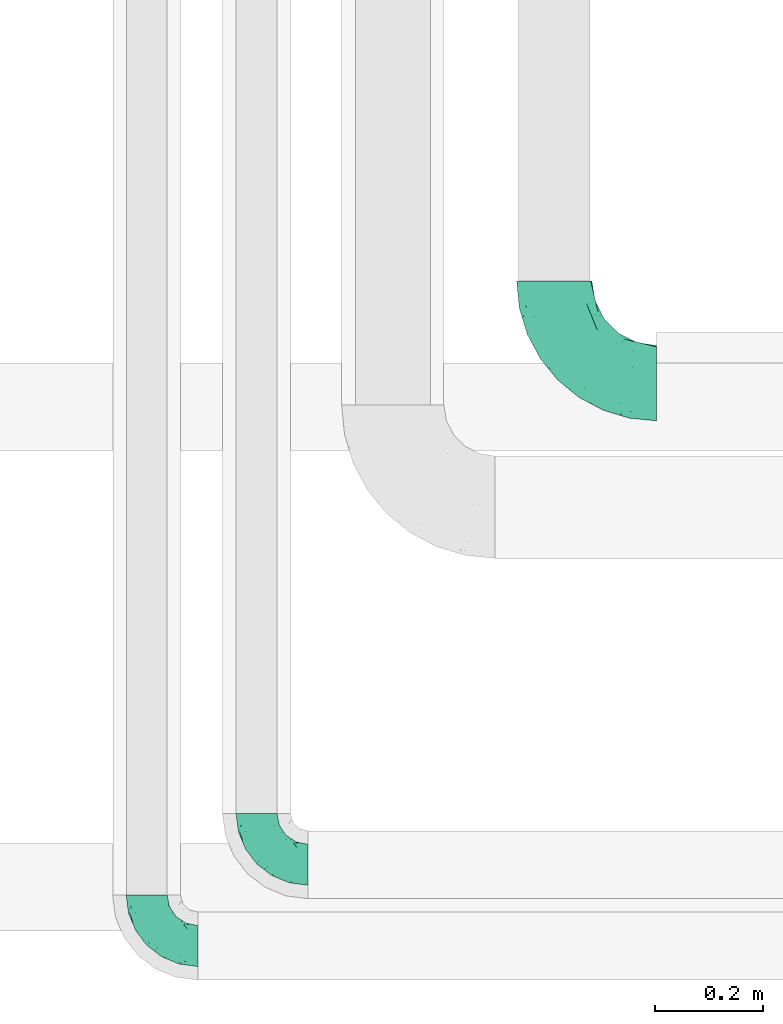
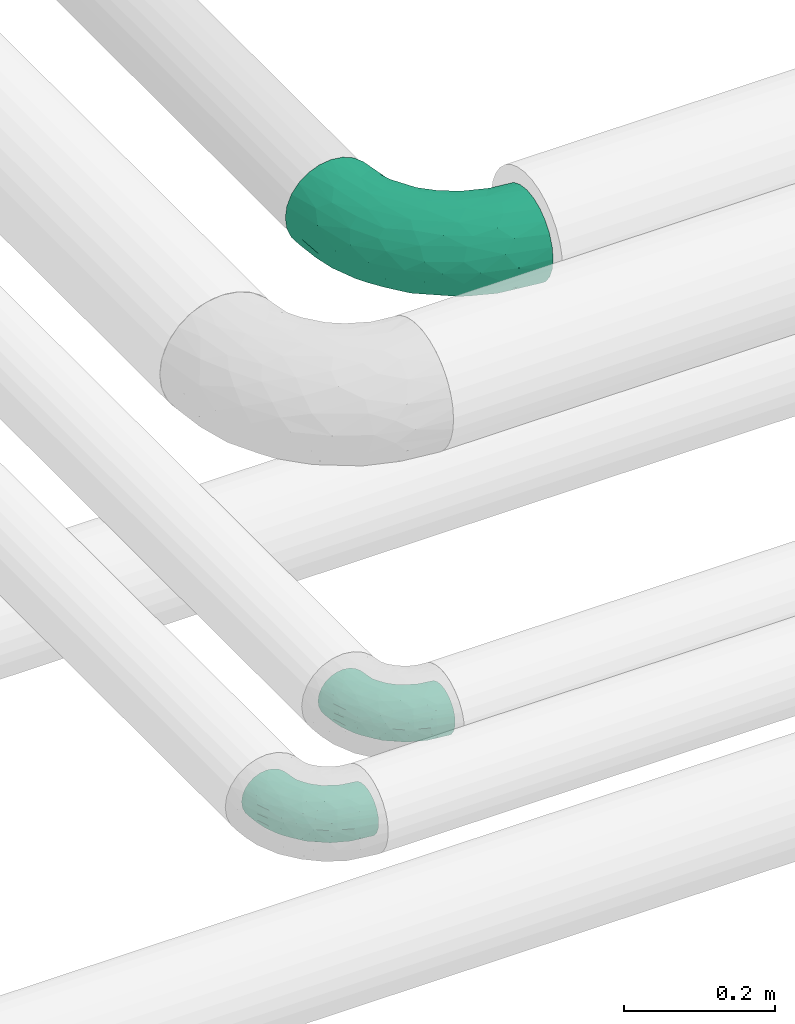
# One storey, part 551 of 827: 3 flow fittings.
"""IFC2X3 building model written with IfcOpenShell, lengths in millimetres."""

from ifc_helpers import new_model, entity, si_unit, converted_unit, derived_unit, direction, frame, origin, place, context, subcontext, project, spatial, faceted_brep, source, transform, mapped, material, type_object, type_shapes, element, save


model = new_model("IFC2X3")

# Units and contexts
model_context = context("Model", 3, precision=0.01, world=origin(), true_north=direction((6.12303176911189e-17, 1.0)))
body_context = subcontext(model_context, "Body", "Model", "MODEL_VIEW")
ifc_project = project(units=[si_unit("LENGTHUNIT", "METRE", prefix="MILLI"), si_unit("AREAUNIT", "SQUARE_METRE"), si_unit("VOLUMEUNIT", "CUBIC_METRE"), converted_unit("PLANEANGLEUNIT", "DEGREE", entity("IfcRatioMeasure", 0.0174532925199433), si_unit("PLANEANGLEUNIT", "RADIAN"), dimensions=[0, 0, 0, 0, 0, 0, 0]), si_unit("MASSUNIT", "GRAM", prefix="KILO"), derived_unit("MASSDENSITYUNIT", [(si_unit("MASSUNIT", "GRAM", prefix="KILO"), 1), (si_unit("LENGTHUNIT", "METRE"), -3)]), derived_unit("MOMENTOFINERTIAUNIT", [(si_unit("LENGTHUNIT", "METRE"), 4)]), si_unit("TIMEUNIT", "SECOND"), si_unit("FREQUENCYUNIT", "HERTZ"), si_unit("THERMODYNAMICTEMPERATUREUNIT", "DEGREE_CELSIUS"), derived_unit("THERMALTRANSMITTANCEUNIT", [(si_unit("MASSUNIT", "GRAM", prefix="KILO"), 1), (si_unit("THERMODYNAMICTEMPERATUREUNIT", "KELVIN"), -1), (si_unit("TIMEUNIT", "SECOND"), -3)]), derived_unit("VOLUMETRICFLOWRATEUNIT", [(si_unit("LENGTHUNIT", "METRE"), 3), (si_unit("TIMEUNIT", "SECOND"), -1)]), derived_unit("MASSFLOWRATEUNIT", [(si_unit("MASSUNIT", "GRAM", prefix="KILO"), 1), (si_unit("TIMEUNIT", "SECOND"), -1)]), derived_unit("ROTATIONALFREQUENCYUNIT", [(si_unit("TIMEUNIT", "SECOND"), -1)]), si_unit("ELECTRICCURRENTUNIT", "AMPERE"), si_unit("ELECTRICVOLTAGEUNIT", "VOLT"), si_unit("POWERUNIT", "WATT"), si_unit("FORCEUNIT", "NEWTON", prefix="KILO"), si_unit("ILLUMINANCEUNIT", "LUX"), si_unit("LUMINOUSFLUXUNIT", "LUMEN"), si_unit("LUMINOUSINTENSITYUNIT", "CANDELA"), derived_unit("USERDEFINED", [(si_unit("MASSUNIT", "GRAM", prefix="KILO"), -1), (si_unit("LENGTHUNIT", "METRE"), -2), (si_unit("TIMEUNIT", "SECOND"), 3), (si_unit("LUMINOUSFLUXUNIT", "LUMEN"), 1)]), derived_unit("LINEARVELOCITYUNIT", [(si_unit("LENGTHUNIT", "METRE"), 1), (si_unit("TIMEUNIT", "SECOND"), -1)]), si_unit("PRESSUREUNIT", "PASCAL"), derived_unit("USERDEFINED", [(si_unit("LENGTHUNIT", "METRE"), -2), (si_unit("MASSUNIT", "GRAM", prefix="KILO"), 1), (si_unit("TIMEUNIT", "SECOND"), -2)]), derived_unit("LINEARFORCEUNIT", [(si_unit("MASSUNIT", "GRAM", prefix="KILO"), 1), (si_unit("LENGTHUNIT", "METRE"), 1), (si_unit("TIMEUNIT", "SECOND"), -2), (si_unit("LENGTHUNIT", "METRE"), -1)]), derived_unit("PLANARFORCEUNIT", [(si_unit("MASSUNIT", "GRAM", prefix="KILO"), 1), (si_unit("LENGTHUNIT", "METRE"), 1), (si_unit("TIMEUNIT", "SECOND"), -2), (si_unit("LENGTHUNIT", "METRE"), -2)])], contexts=[model_context])

# Site, building, storey
site_placement = place(None, origin())
site = spatial("IfcSite", under=ifc_project, at=site_placement, CompositionType="ELEMENT")
building_placement = place(site_placement, origin())
building = spatial("IfcBuilding", under=site, at=building_placement, CompositionType="ELEMENT")
storey_placement = place(building_placement, frame((0.0, 0.0, 28200.0)))
storey = spatial("IfcBuildingStorey", under=building, at=storey_placement, Name="08", CompositionType="ELEMENT", Elevation=28200.0)

# Flow fittings
ifc_material = material()
pipe_fitting_type_1 = type_object("IfcPipeFittingType", Name="ADSK_1", PredefinedType="NOTDEFINED", material=ifc_material)
shared_shape_1 = source(origin(), body_context, "Body", "Brep", [
    faceted_brep([(-95.0, 19.02, -32.95), (-95.0, 9.85, -36.75), (-95.0, 0.0, -38.05), (-95.0, -9.85, -36.75), (-95.0, -19.03, -32.95), (-95.0, -26.91, -26.91), (-95.0, -32.95, -19.03), (-95.0, -36.75, -9.85), (-95.0, -38.05, 0.0), (-95.0, -36.75, 9.85), (-95.0, -32.95, 19.02), (-95.0, -26.91, 26.91), (-95.0, -19.03, 32.95), (-95.0, -9.85, 36.75), (-95.0, 0.0, 38.05), (-95.0, 9.85, 36.75), (-95.0, 19.02, 32.95), (-95.0, 26.91, 26.91), (-95.0, 32.95, 19.02), (-95.0, 36.75, 9.85), (-95.0, 38.05, 0.0), (-95.0, 36.75, -9.85), (-95.0, 32.95, -19.03), (-95.0, 26.91, -26.91), (0.0, 95.0, -38.05), (-9.85, 95.0, -36.75), (-19.02, 95.0, -32.95), (-26.91, 95.0, -26.91), (-32.95, 95.0, -19.03), (-36.75, 95.0, -9.85), (-38.05, 95.0, 0.0), (-36.75, 95.0, 9.85), (-32.95, 95.0, 19.02), (-26.91, 95.0, 26.91), (-19.02, 95.0, 32.95), (-9.85, 95.0, 36.75), (0.0, 95.0, 38.05), (9.85, 95.0, 36.75), (19.03, 95.0, 32.95), (26.91, 95.0, 26.91), (32.95, 95.0, 19.02), (36.75, 95.0, 9.85), (38.05, 95.0, 0.0), (36.75, 95.0, -9.85), (32.95, 95.0, -19.03), (26.91, 95.0, -26.91), (19.03, 95.0, -32.95), (9.85, 95.0, -36.75), (-7.99, -4.96, 6.3), (-0.92, 0.92, 0.0), (4.62, 8.1, 8.01), (-76.19, -35.57, 0.0), (-64.32, -32.32, 12.43), (20.51, 62.45, 28.68), (-60.56, -33.52, 0.0), (-70.4, -13.47, 34.42), (-39.61, -5.88, 32.32), (-49.6, 2.07, 37.1), (-70.34, -28.81, 21.71), (14.64, 40.81, 26.5), (5.88, 39.61, 32.32), (3.59, 20.77, 25.31), (-40.45, 68.06, 16.75), (-62.45, -20.51, 28.68), (-44.52, -26.87, 0.0), (-28.47, -20.22, 0.0), (-26.43, -17.83, 8.75), (-76.1, 39.63, 10.76), (-72.74, 37.58, 18.19), (-60.35, 46.18, 14.61), (-13.4, 13.4, 32.12), (-20.77, -3.59, 25.31), (-14.66, 81.47, 35.56), (-6.22, 71.26, 37.92), (-57.5, 42.48, 22.79), (-15.0, 34.74, 37.7), (-27.1, 12.08, 36.05), (-9.2, 28.81, 35.63), (-79.98, 23.7, 30.95), (-73.68, -4.3, 37.48), (-30.74, 21.67, 37.97), (-62.36, 47.59, 6.79), (-72.71, 32.83, 24.69), (-67.42, 7.02, 37.95), (-32.13, 75.27, 24.51), (-43.46, 51.47, 26.26), (-24.98, 73.15, 31.29), (20.59, 41.28, 19.85), (7.79, 16.09, 15.86), (-73.21, 42.39, 0.0), (-54.73, 54.73, 0.0), (-73.44, 15.79, 35.79), (-5.94, 4.32, 20.43), (28.81, 70.34, 21.71), (32.32, 64.32, 12.43), (-53.59, 26.2, 35.09), (-52.02, 19.31, 37.21), (21.38, 33.53, 10.34), (26.87, 44.52, 0.0), (-48.28, 12.14, 38.05), (4.3, 73.68, 37.48), (-44.08, -25.52, 12.79), (-41.28, -20.59, 19.85), (35.57, 76.19, 0.0), (-47.26, 54.3, 20.18), (-47.4, 61.99, 8.58), (-42.39, 73.21, 0.0), (-39.67, 78.86, 7.21), (-45.69, 36.84, 33.11), (-32.83, 50.13, 33.35), (13.47, 70.4, 34.42), (-18.25, 63.73, 36.07), (-40.63, -13.75, 27.22), (-16.63, 46.37, 37.95), (-53.47, 38.79, 28.59), (-26.07, 48.54, 36.15), (-34.51, 34.51, 36.86), (-2.07, 49.6, 37.1), (-22.79, -10.49, 19.23), (-61.73, 28.67, 31.87), (9.65, 14.7, 0.0), (20.22, 28.47, 0.0), (33.52, 60.56, 0.0), (-11.42, -5.44, 13.25), (-14.7, -9.65, 0.0), (-81.47, 14.66, -35.56), (-62.45, -20.51, -28.68), (-71.26, 6.22, -37.92), (-75.27, 32.13, -24.51), (-73.15, 24.98, -31.29), (13.47, 70.4, -34.42), (5.88, 39.61, -32.32), (-2.07, 49.6, -37.1), (-78.86, 39.67, -7.21), (-70.4, -13.47, -34.42), (-39.61, -5.88, -32.32), (-61.99, 47.4, -8.58), (32.32, 64.32, -12.43), (28.81, 70.34, -21.71), (-63.73, 18.25, -36.07), (-50.13, 32.83, -33.35), (4.3, 73.68, -37.48), (-7.02, 67.42, -37.95), (-39.63, 76.1, -10.76), (-46.18, 60.35, -14.61), (-47.59, 62.36, -6.79), (-64.32, -32.32, -12.43), (-26.2, 53.59, -35.09), (-15.79, 73.44, -35.79), (-19.31, 52.02, -37.21), (-37.58, 72.74, -18.19), (-70.34, -28.81, -21.71), (-42.48, 57.5, -22.79), (-38.79, 53.47, -28.59), (-51.47, 43.46, -26.26), (-32.83, 72.71, -24.69), (-46.37, 16.63, -37.95), (-73.68, -4.3, -37.48), (-41.28, -20.59, -19.85), (-44.08, -25.52, -12.79), (13.75, 40.63, -27.22), (20.51, 62.45, -28.68), (-68.06, 40.45, -16.75), (-54.3, 47.26, -20.18), (-12.14, 48.28, -38.05), (-21.67, 30.74, -37.97), (-36.84, 45.69, -33.11), (-11.42, -5.44, -13.25), (7.79, 16.09, -15.86), (4.62, 8.1, -8.01), (-23.7, 79.98, -30.95), (-26.43, -17.83, -8.75), (-7.99, -4.96, -6.3), (-40.81, -14.64, -26.5), (-20.77, -3.59, -25.31), (-34.74, 15.0, -37.7), (-12.08, 27.1, -36.05), (-28.81, 9.2, -35.63), (-22.79, -10.49, -19.23), (21.38, 33.53, -10.34), (20.59, 41.28, -19.85), (-48.54, 26.07, -36.15), (-49.6, 2.07, -37.1), (-13.4, 13.4, -32.12), (3.59, 20.77, -25.31), (-28.67, 61.73, -31.87), (-34.51, 34.51, -36.86), (-5.94, 4.32, -20.43)], [[[0, 1, 2, 3, 4, 5, 6, 7, 8, 9, 10, 11, 12, 13, 14, 15, 16, 17, 18, 19, 20, 21, 22, 23]], [[24, 25, 26, 27, 28, 29, 30, 31, 32, 33, 34, 35, 36, 37, 38, 39, 40, 41, 42, 43, 44, 45, 46, 47]], [[48, 49, 50]], [[51, 52, 9]], [[53, 39, 38]], [[9, 52, 10]], [[54, 52, 51]], [[55, 56, 57]], [[11, 10, 58]], [[59, 60, 61]], [[32, 31, 62]], [[63, 12, 11]], [[63, 55, 12]], [[64, 65, 66]], [[67, 68, 69]], [[70, 56, 71]], [[35, 72, 73]], [[69, 68, 74]], [[75, 76, 77]], [[16, 78, 17]], [[13, 79, 14]], [[76, 75, 80]], [[67, 69, 81]], [[18, 17, 82]], [[14, 79, 83]], [[20, 19, 67]], [[84, 85, 86]], [[87, 61, 88]], [[89, 81, 90]], [[18, 82, 68]], [[15, 91, 16]], [[14, 83, 15]], [[71, 92, 61]], [[17, 78, 82]], [[93, 87, 94]], [[95, 91, 96]], [[97, 98, 94]], [[86, 72, 34]], [[96, 99, 80]], [[37, 36, 100]], [[40, 39, 93]], [[40, 94, 41]], [[64, 66, 101]], [[93, 94, 40]], [[58, 102, 63]], [[94, 103, 41]], [[94, 87, 97]], [[104, 69, 74]], [[34, 33, 86]], [[105, 69, 104]], [[52, 58, 10]], [[106, 107, 30]], [[108, 109, 85]], [[105, 106, 90]], [[53, 110, 60]], [[86, 111, 72]], [[86, 109, 111]], [[33, 84, 86]], [[12, 55, 13]], [[112, 56, 63]], [[110, 38, 37]], [[34, 72, 35]], [[36, 35, 73]], [[111, 113, 73]], [[105, 107, 106]], [[110, 53, 38]], [[74, 114, 85]], [[91, 15, 83]], [[105, 90, 81]], [[107, 62, 31]], [[33, 32, 84]], [[115, 109, 116]], [[111, 115, 113]], [[100, 73, 117]], [[56, 55, 63]], [[79, 55, 57]], [[102, 118, 112]], [[56, 70, 76]], [[100, 110, 37]], [[117, 77, 60]], [[117, 60, 110]], [[60, 70, 61]], [[58, 52, 101]], [[63, 11, 58]], [[39, 53, 93]], [[87, 93, 53]], [[96, 91, 83]], [[78, 91, 119]], [[32, 62, 84]], [[84, 62, 104]], [[86, 85, 109]], [[85, 114, 108]], [[80, 113, 116]], [[117, 73, 113]], [[80, 116, 96]], [[80, 57, 76]], [[71, 112, 118]], [[61, 87, 59]], [[62, 107, 105]], [[97, 120, 121]], [[70, 71, 61]], [[71, 118, 92]], [[73, 100, 36]], [[110, 100, 117]], [[55, 79, 13]], [[83, 79, 57]], [[96, 83, 99]], [[116, 108, 95]], [[50, 97, 88]], [[97, 87, 88]], [[50, 49, 120]], [[122, 94, 98]], [[89, 20, 67]], [[105, 81, 69]], [[89, 67, 81]], [[68, 19, 18]], [[68, 67, 19]], [[74, 68, 82]], [[114, 82, 119]], [[74, 85, 104]], [[82, 114, 74]], [[114, 119, 108]], [[95, 108, 119]], [[116, 109, 108]], [[123, 48, 50]], [[97, 50, 120]], [[123, 50, 88]], [[91, 95, 119]], [[116, 95, 96]], [[84, 104, 85]], [[104, 62, 105]], [[83, 57, 99]], [[57, 80, 99]], [[66, 48, 123]], [[66, 124, 48]], [[118, 66, 123]], [[124, 66, 65]], [[66, 118, 101]], [[54, 64, 52]], [[124, 49, 48]], [[30, 107, 31]], [[91, 78, 16]], [[82, 78, 119]], [[56, 76, 57]], [[77, 76, 70]], [[60, 77, 70]], [[77, 117, 75]], [[117, 113, 75]], [[113, 80, 75]], [[9, 8, 51]], [[103, 94, 122]], [[103, 42, 41]], [[73, 72, 111]], [[113, 115, 116]], [[111, 109, 115]], [[102, 112, 63]], [[71, 56, 112]], [[118, 102, 101]], [[92, 123, 88]], [[123, 92, 118]], [[61, 92, 88]], [[87, 53, 59]], [[60, 59, 53]], [[97, 121, 98]], [[58, 101, 102]], [[64, 101, 52]], [[125, 1, 0]], [[126, 5, 4]], [[2, 1, 127]], [[1, 125, 127]], [[128, 129, 23]], [[130, 131, 132]], [[89, 133, 20]], [[126, 134, 135]], [[136, 89, 90]], [[137, 138, 44]], [[139, 129, 140]], [[24, 141, 142]], [[143, 144, 145]], [[125, 129, 139]], [[6, 146, 7]], [[147, 148, 149]], [[146, 51, 7]], [[143, 150, 144]], [[146, 6, 151]], [[152, 153, 154]], [[126, 4, 134]], [[0, 23, 129]], [[28, 155, 150]], [[43, 42, 103]], [[54, 146, 64]], [[139, 156, 127]], [[157, 3, 2]], [[151, 158, 159]], [[160, 131, 161]], [[22, 21, 162]], [[136, 144, 163]], [[149, 164, 165]], [[24, 142, 25]], [[166, 140, 154]], [[154, 129, 128]], [[143, 30, 29]], [[167, 168, 169]], [[155, 28, 27]], [[26, 170, 27]], [[171, 167, 172]], [[26, 25, 148]], [[27, 170, 155]], [[173, 135, 174]], [[144, 150, 152]], [[175, 176, 177]], [[24, 47, 141]], [[45, 161, 46]], [[148, 25, 142]], [[176, 175, 165]], [[64, 159, 171]], [[138, 45, 44]], [[130, 46, 161]], [[137, 44, 43]], [[178, 159, 158]], [[137, 103, 122]], [[163, 144, 152]], [[136, 133, 89]], [[103, 137, 43]], [[6, 5, 151]], [[178, 158, 173]], [[134, 4, 3]], [[178, 173, 174]], [[137, 98, 179]], [[145, 90, 106]], [[138, 180, 161]], [[46, 130, 47]], [[136, 90, 145]], [[133, 162, 21]], [[23, 22, 128]], [[139, 140, 181]], [[139, 181, 156]], [[157, 127, 182]], [[157, 134, 3]], [[182, 177, 135]], [[182, 135, 134]], [[135, 183, 174]], [[131, 130, 161]], [[141, 130, 132]], [[160, 180, 184]], [[131, 183, 176]], [[5, 126, 151]], [[158, 151, 126]], [[180, 138, 137]], [[161, 45, 138]], [[149, 148, 142]], [[170, 148, 185]], [[22, 162, 128]], [[128, 162, 163]], [[129, 154, 140]], [[154, 153, 166]], [[165, 156, 186]], [[182, 127, 156]], [[165, 186, 149]], [[165, 132, 176]], [[131, 184, 183]], [[187, 167, 178]], [[184, 168, 187]], [[167, 169, 172]], [[184, 180, 168]], [[174, 183, 184]], [[127, 157, 2]], [[134, 157, 182]], [[130, 141, 47]], [[142, 141, 132]], [[149, 142, 164]], [[186, 166, 147]], [[180, 179, 168]], [[169, 179, 120]], [[137, 179, 180]], [[179, 121, 120]], [[106, 30, 143]], [[136, 145, 144]], [[106, 143, 145]], [[150, 29, 28]], [[150, 143, 29]], [[152, 150, 155]], [[153, 155, 185]], [[152, 154, 163]], [[155, 153, 152]], [[153, 185, 166]], [[147, 166, 185]], [[186, 140, 166]], [[169, 120, 49]], [[169, 49, 172]], [[179, 169, 168]], [[148, 147, 185]], [[186, 147, 149]], [[128, 163, 154]], [[163, 162, 136]], [[142, 132, 164]], [[132, 165, 164]], [[171, 124, 65]], [[124, 171, 172]], [[64, 146, 159]], [[171, 159, 178]], [[171, 65, 64]], [[172, 49, 124]], [[162, 133, 136]], [[20, 133, 21]], [[148, 170, 26]], [[155, 170, 185]], [[131, 176, 132]], [[177, 176, 183]], [[135, 177, 183]], [[177, 182, 175]], [[182, 156, 175]], [[156, 165, 175]], [[51, 146, 54]], [[51, 8, 7]], [[129, 125, 0]], [[127, 125, 139]], [[140, 186, 181]], [[156, 181, 186]], [[158, 126, 173]], [[135, 173, 126]], [[187, 178, 174]], [[171, 178, 167]], [[184, 187, 174]], [[167, 187, 168]], [[180, 160, 161]], [[184, 131, 160]], [[98, 137, 122]], [[98, 121, 179]], [[151, 159, 146]]]),
])
type_shapes(pipe_fitting_type_1, [shared_shape_1])
for number, where, z_axis, x_axis, name in (
    (1, (26663.64, 6265.71, 3100.0), (0.0, 0.0, 1.0), (0.0, -1.0, 0.0), "ADSK_1"),
    (2, (26867.64, 6416.57, 3100.0), (0.0, 0.0, 1.0), (0.0, -1.0, 0.0), "ADSK_1"),
):
    element("IfcFlowFitting", number, at=place(storey_placement, frame(where, z_axis=z_axis, x_axis=x_axis)), inside=storey, type_object=pipe_fitting_type_1, material=ifc_material, Name=name, ObjectType="ADSK_1", context=body_context, shape_type="MappedRepresentation", body=[
        mapped(shared_shape_1, transform((0.0, 0.0, 0.0), scale=1.0)),
    ])
pipe_fitting_type_2 = type_object("IfcPipeFittingType", Name="ADSK_1", PredefinedType="NOTDEFINED", material=ifc_material)
shared_shape_2 = source(origin(), body_context, "Body", "Brep", [
    faceted_brep([(-190.0, 18.08, -67.47), (-190.0, 0.0, -69.85), (-190.0, -18.08, -67.47), (-190.0, -34.93, -60.49), (-190.0, -49.39, -49.39), (-190.0, -60.49, -34.93), (-190.0, -67.47, -18.08), (-190.0, -69.85, 0.0), (-190.0, -67.47, 18.08), (-190.0, -60.49, 34.92), (-190.0, -49.39, 49.39), (-190.0, -34.93, 60.49), (-190.0, -18.08, 67.47), (-190.0, 0.0, 69.85), (-190.0, 18.08, 67.47), (-190.0, 34.92, 60.49), (-190.0, 49.39, 49.39), (-190.0, 60.49, 34.92), (-190.0, 67.47, 18.08), (-190.0, 69.85, 0.0), (-190.0, 67.47, -18.08), (-190.0, 60.49, -34.93), (-190.0, 49.39, -49.39), (-190.0, 34.92, -60.49), (18.08, 190.0, -67.47), (0.0, 190.0, -69.85), (-18.08, 190.0, -67.47), (-34.92, 190.0, -60.49), (-49.39, 190.0, -49.39), (-60.49, 190.0, -34.93), (-67.47, 190.0, -18.08), (-69.85, 190.0, 0.0), (-67.47, 190.0, 18.08), (-60.49, 190.0, 34.92), (-49.39, 190.0, 49.39), (-34.92, 190.0, 60.49), (-18.08, 190.0, 67.47), (0.0, 190.0, 69.85), (18.08, 190.0, 67.47), (34.93, 190.0, 60.49), (49.39, 190.0, 49.39), (60.49, 190.0, 34.92), (67.47, 190.0, 18.08), (69.85, 190.0, 0.0), (67.47, 190.0, -18.08), (60.49, 190.0, -34.93), (49.39, 190.0, -49.39), (34.93, 190.0, -60.49), (-29.62, 146.98, 65.62), (-13.75, 135.37, 69.64), (-124.22, -36.33, 52.83), (-140.23, -52.18, 40.04), (-80.56, -34.09, 36.78), (-140.97, -24.01, 63.29), (-80.93, -8.05, 59.8), (-100.59, 5.62, 68.24), (-125.19, -57.65, 22.9), (-139.31, -64.86, 0.0), (-28.7, -8.91, 22.6), (-45.64, -26.06, 0.0), (-6.26, 6.26, 0.0), (-105.44, 36.89, 68.2), (-118.83, 43.56, 64.34), (-146.98, 29.62, 65.62), (-71.47, -38.86, 17.07), (-90.56, -50.07, 0.0), (-0.6, 27.02, 35.97), (-44.76, -2.31, 47.74), (-42.86, -12.1, 35.78), (-148.03, -7.38, 68.85), (-135.37, 13.75, 69.64), (-67.48, 159.11, 28.79), (36.32, 124.15, 52.82), (-38.8, 102.11, 68.2), (-24.59, 96.61, 69.85), (-81.73, 130.22, 21.92), (-65.15, 30.31, 68.68), (-27.72, 54.52, 66.49), (-44.98, 61.25, 69.74), (-75.73, 152.87, 0.0), (-159.11, 67.48, 28.79), (-130.22, 81.73, 21.92), (-152.87, 75.73, 0.0), (-76.65, 126.59, 35.57), (-101.51, 101.51, 25.92), (-96.74, 96.74, 38.75), (-144.94, 60.97, 45.11), (-159.57, 43.91, 56.71), (-119.38, 92.8, 0.0), (50.07, 90.56, 0.0), (57.42, 124.25, 22.84), (38.8, 71.6, 17.49), (64.86, 139.31, 0.0), (52.17, 140.21, 40.03), (33.37, 79.39, 36.99), (24.0, 140.95, 63.29), (8.03, 80.92, 59.81), (-82.61, -22.17, 50.94), (7.38, 148.03, 68.85), (-100.26, 79.14, 51.33), (-75.76, 96.1, 55.72), (-76.12, 111.95, 46.7), (-92.8, 119.38, 0.0), (-104.27, 104.27, 12.31), (10.07, 27.17, 16.15), (26.06, 45.64, 0.0), (-61.21, 144.14, 45.16), (-44.13, 158.15, 56.77), (-55.26, 120.41, 58.38), (9.95, 57.03, 48.64), (29.48, 90.08, 47.56), (-5.62, 100.59, 68.24), (-122.78, 54.24, 58.28), (-86.25, 73.26, 61.12), (-95.79, 24.47, 69.85), (-126.59, 76.65, 35.57), (-17.15, 26.56, 50.85), (-29.82, 29.82, 59.54), (-70.73, 11.02, 65.19), (-58.6, 94.58, 64.16), (-71.14, 66.1, 67.41), (-158.15, 44.13, -56.77), (33.37, 79.39, -36.99), (10.07, 27.17, -16.15), (-0.6, 27.02, -35.97), (-100.59, 5.62, -68.24), (-148.03, -7.38, -68.85), (-135.37, 13.75, -69.64), (-130.22, 81.73, -21.92), (-146.98, 29.62, -65.62), (-102.11, 38.8, -68.2), (-96.61, 24.59, -69.85), (-83.02, -24.86, -48.76), (-44.76, -2.31, -47.74), (-80.56, -34.09, -36.78), (-122.68, -57.24, -22.15), (-71.43, -38.87, -16.95), (-104.27, 104.27, -12.31), (-159.11, 67.48, -28.79), (-144.14, 61.21, -45.16), (7.38, 148.03, -68.85), (-13.75, 135.37, -69.64), (-79.14, 100.26, -51.33), (-96.1, 75.76, -55.72), (-111.95, 76.12, -46.7), (-80.93, -8.05, -59.8), (-124.22, -36.33, -52.83), (-140.23, -52.18, -40.04), (-24.47, 95.79, -69.85), (-36.89, 105.44, -68.2), (-150.18, -65.36, -13.92), (-43.56, 118.83, -64.34), (-29.62, 146.98, -65.62), (38.8, 71.6, -17.49), (-81.73, 130.22, -21.92), (-28.7, -8.91, -22.6), (-54.24, 122.78, -58.28), (-73.26, 86.25, -61.12), (-61.25, 44.98, -69.74), (-30.31, 65.15, -68.68), (-54.52, 27.72, -66.49), (-101.51, 101.51, -25.92), (-126.59, 76.65, -35.57), (-96.74, 96.74, -38.75), (-67.48, 159.11, -28.79), (-120.41, 55.26, -58.38), (-43.91, 159.57, -56.71), (24.0, 140.95, -63.29), (8.03, 80.92, -59.81), (-5.62, 100.59, -68.24), (-60.97, 144.94, -45.11), (36.32, 124.15, -52.82), (57.42, 124.25, -22.84), (52.17, 140.21, -40.03), (-140.97, -24.01, -63.29), (9.95, 57.03, -48.64), (-76.65, 126.59, -35.57), (22.84, 89.04, -52.94), (-11.03, 70.74, -65.2), (-29.82, 29.82, -59.54), (-94.58, 58.6, -64.16), (-66.1, 71.14, -67.41), (-31.42, -3.01, -36.09), (-13.88, 24.32, -46.86)], [[[0, 1, 2, 3, 4, 5, 6, 7, 8, 9, 10, 11, 12, 13, 14, 15, 16, 17, 18, 19, 20, 21, 22, 23]], [[24, 25, 26, 27, 28, 29, 30, 31, 32, 33, 34, 35, 36, 37, 38, 39, 40, 41, 42, 43, 44, 45, 46, 47]], [[36, 48, 49]], [[50, 51, 52]], [[53, 54, 55]], [[56, 9, 8]], [[8, 7, 57]], [[58, 59, 60]], [[51, 9, 56]], [[61, 62, 63]], [[59, 58, 64]], [[59, 64, 65]], [[11, 10, 50]], [[66, 67, 68]], [[50, 53, 11]], [[69, 70, 13]], [[71, 33, 32]], [[72, 40, 39]], [[73, 74, 49]], [[63, 15, 14]], [[13, 70, 14]], [[71, 32, 75]], [[12, 69, 13]], [[76, 77, 78]], [[32, 79, 75]], [[18, 80, 81]], [[63, 14, 70]], [[82, 19, 18]], [[83, 84, 85]], [[86, 16, 87]], [[82, 81, 88]], [[82, 18, 81]], [[15, 87, 16]], [[83, 71, 75]], [[52, 56, 64]], [[49, 37, 36]], [[89, 90, 91]], [[36, 35, 48]], [[42, 41, 90]], [[89, 92, 90]], [[11, 53, 12]], [[73, 78, 74]], [[65, 56, 57]], [[40, 72, 93]], [[94, 90, 93]], [[41, 40, 93]], [[72, 95, 96]], [[95, 39, 38]], [[8, 57, 56]], [[43, 42, 92]], [[67, 54, 97]], [[38, 37, 98]], [[99, 100, 101]], [[102, 75, 79]], [[51, 10, 9]], [[102, 88, 103]], [[31, 79, 32]], [[104, 60, 105]], [[106, 34, 33]], [[84, 103, 81]], [[91, 105, 89]], [[107, 35, 34]], [[106, 108, 107]], [[49, 48, 73]], [[104, 105, 91]], [[16, 86, 17]], [[58, 104, 66]], [[109, 110, 96]], [[111, 98, 49]], [[112, 113, 99]], [[92, 42, 90]], [[95, 72, 39]], [[70, 114, 61]], [[80, 18, 17]], [[101, 106, 83]], [[99, 86, 112]], [[115, 81, 80]], [[90, 94, 91]], [[94, 66, 104]], [[64, 58, 68]], [[56, 65, 64]], [[93, 72, 110]], [[90, 41, 93]], [[98, 95, 38]], [[111, 77, 96]], [[111, 96, 95]], [[67, 116, 117]], [[52, 51, 56]], [[50, 10, 51]], [[54, 53, 50]], [[69, 53, 55]], [[97, 52, 67]], [[118, 76, 55]], [[107, 48, 35]], [[73, 119, 120]], [[61, 63, 70]], [[63, 62, 87]], [[94, 104, 91]], [[58, 60, 104]], [[109, 66, 94]], [[67, 117, 54]], [[68, 67, 52]], [[116, 66, 109]], [[119, 48, 108]], [[73, 120, 78]], [[120, 61, 114]], [[78, 114, 76]], [[49, 98, 37]], [[95, 98, 111]], [[53, 69, 12]], [[70, 69, 55]], [[70, 55, 114]], [[120, 113, 62]], [[76, 114, 55]], [[120, 114, 78]], [[118, 55, 54]], [[76, 118, 77]], [[96, 77, 117]], [[111, 78, 77]], [[54, 117, 118]], [[77, 118, 117]], [[110, 109, 94]], [[116, 96, 117]], [[106, 107, 34]], [[48, 107, 108]], [[75, 84, 83]], [[106, 33, 71]], [[101, 83, 85]], [[106, 71, 83]], [[99, 101, 85]], [[108, 106, 101]], [[99, 85, 115]], [[113, 112, 62]], [[119, 113, 120]], [[100, 99, 113]], [[17, 86, 80]], [[115, 85, 84]], [[80, 86, 115]], [[99, 115, 86]], [[63, 87, 15]], [[86, 87, 112]], [[78, 111, 74]], [[111, 49, 74]], [[119, 100, 113]], [[101, 100, 108]], [[48, 119, 73]], [[119, 108, 100]], [[75, 102, 103]], [[115, 84, 81]], [[81, 103, 88]], [[75, 103, 84]], [[54, 50, 97]], [[52, 97, 50]], [[64, 68, 52]], [[66, 68, 58]], [[62, 61, 120]], [[87, 62, 112]], [[93, 110, 94]], [[96, 110, 72]], [[66, 116, 67]], [[96, 116, 109]], [[22, 121, 23]], [[122, 123, 124]], [[125, 126, 127]], [[20, 82, 128]], [[129, 130, 127]], [[130, 131, 127]], [[19, 82, 20]], [[132, 133, 134]], [[88, 128, 82]], [[135, 136, 65]], [[102, 137, 88]], [[138, 20, 128]], [[139, 22, 21]], [[140, 141, 25]], [[142, 143, 144]], [[145, 133, 132]], [[4, 146, 147]], [[141, 148, 149]], [[7, 6, 150]], [[138, 21, 20]], [[5, 4, 147]], [[149, 151, 152]], [[59, 65, 136]], [[122, 153, 123]], [[79, 30, 154]], [[134, 155, 136]], [[150, 65, 57]], [[156, 157, 142]], [[126, 2, 1]], [[134, 135, 147]], [[130, 158, 131]], [[159, 160, 158]], [[154, 161, 137]], [[0, 23, 129]], [[127, 1, 0]], [[162, 138, 128]], [[161, 163, 162]], [[30, 79, 31]], [[146, 4, 3]], [[154, 30, 164]], [[152, 27, 26]], [[165, 121, 139]], [[25, 24, 140]], [[25, 141, 26]], [[164, 30, 29]], [[27, 166, 28]], [[167, 168, 169]], [[141, 152, 26]], [[28, 170, 29]], [[47, 171, 167]], [[172, 89, 153]], [[59, 155, 60]], [[28, 166, 170]], [[46, 45, 173]], [[153, 89, 105]], [[105, 123, 153]], [[174, 146, 3]], [[171, 47, 46]], [[45, 44, 172]], [[7, 150, 57]], [[43, 92, 44]], [[122, 124, 175]], [[89, 172, 92]], [[171, 173, 122]], [[47, 167, 24]], [[173, 171, 46]], [[135, 150, 5]], [[0, 129, 127]], [[174, 3, 2]], [[79, 154, 102]], [[146, 174, 145]], [[44, 92, 172]], [[144, 139, 162]], [[142, 170, 156]], [[176, 154, 164]], [[105, 60, 123]], [[122, 172, 153]], [[45, 172, 173]], [[122, 173, 172]], [[167, 171, 177]], [[140, 167, 169]], [[177, 122, 175]], [[178, 159, 169]], [[134, 136, 135]], [[155, 59, 136]], [[134, 147, 146]], [[135, 5, 147]], [[126, 174, 2]], [[125, 160, 145]], [[125, 145, 174]], [[145, 179, 133]], [[121, 129, 23]], [[130, 180, 181]], [[149, 152, 141]], [[152, 151, 166]], [[60, 155, 123]], [[123, 155, 124]], [[182, 134, 133]], [[175, 179, 168]], [[183, 179, 175]], [[155, 182, 124]], [[180, 129, 165]], [[130, 181, 158]], [[181, 149, 148]], [[158, 148, 159]], [[127, 126, 1]], [[174, 126, 125]], [[167, 140, 24]], [[141, 140, 169]], [[141, 169, 148]], [[181, 157, 151]], [[159, 148, 169]], [[181, 148, 158]], [[178, 169, 168]], [[159, 178, 160]], [[145, 160, 179]], [[125, 158, 160]], [[168, 179, 178]], [[160, 178, 179]], [[175, 124, 183]], [[177, 175, 168]], [[139, 121, 22]], [[129, 121, 165]], [[128, 161, 162]], [[139, 21, 138]], [[144, 162, 163]], [[139, 138, 162]], [[142, 144, 163]], [[165, 139, 144]], [[142, 163, 176]], [[157, 156, 151]], [[180, 157, 181]], [[143, 142, 157]], [[29, 170, 164]], [[176, 163, 161]], [[164, 170, 176]], [[142, 176, 170]], [[152, 166, 27]], [[170, 166, 156]], [[158, 125, 131]], [[125, 127, 131]], [[180, 143, 157]], [[144, 143, 165]], [[129, 180, 130]], [[180, 165, 143]], [[128, 88, 137]], [[176, 161, 154]], [[154, 137, 102]], [[128, 137, 161]], [[5, 150, 6]], [[65, 150, 135]], [[134, 146, 132]], [[145, 132, 146]], [[134, 182, 155]], [[183, 182, 133]], [[151, 149, 181]], [[166, 151, 156]], [[182, 183, 124]], [[179, 183, 133]], [[167, 177, 168]], [[122, 177, 171]]]),
])
type_shapes(pipe_fitting_type_2, [shared_shape_2])
flow_fitting_placement = place(storey_placement, frame((27420.03, 7310.0, 3100.0), z_axis=(0.0, 0.0, 1.0), x_axis=(0.0, -1.0, 0.0)))
element("IfcFlowFitting", 3, at=flow_fitting_placement, inside=storey, type_object=pipe_fitting_type_2, material=ifc_material, Name="ADSK_1", ObjectType="ADSK_1", context=body_context, shape_type="MappedRepresentation", body=[
    mapped(shared_shape_2, transform((0.0, 0.0, 0.0), scale=1.0)),
])

save(model, "model.ifc")
